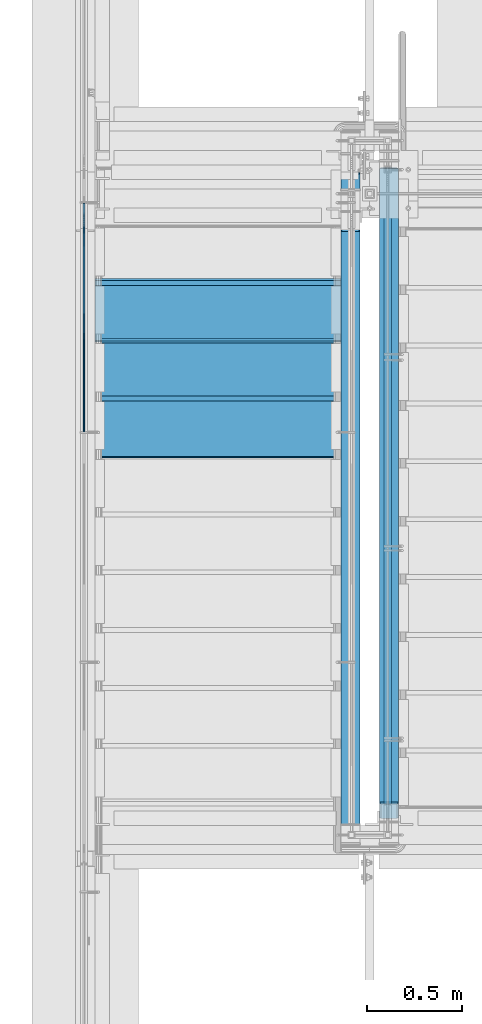
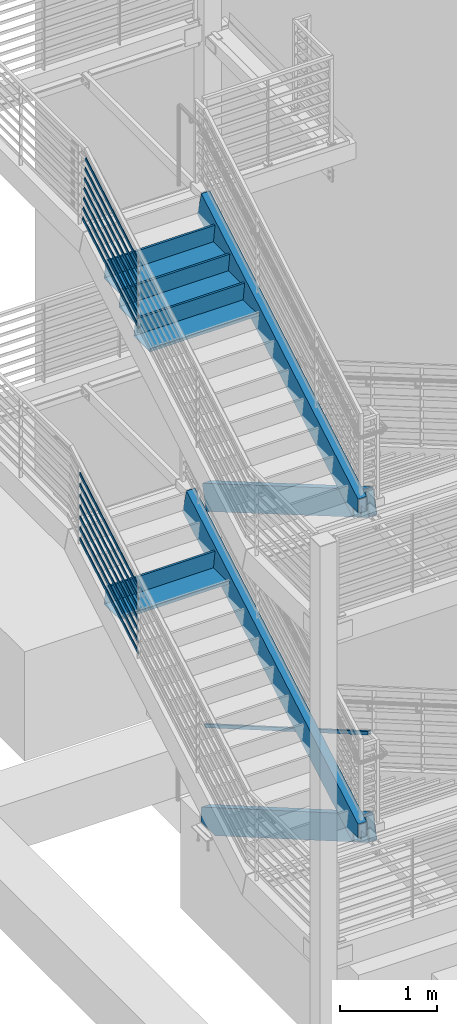
# One storey, part 756 of 1179: 19 members, 4 beams, 7 elements without a shape of their own.
"""IFC2X3 building model written with IfcOpenShell, lengths in millimetres."""

from ifc_helpers import new_model, si_unit, frame, origin_with_axes, place, context, subcontext, project, spatial, faceted_brep, material, type_object, element, aggregate, save


model = new_model("IFC2X3")

# Units and contexts
model_context = context("Model", 3, precision=1e-05, world=origin_with_axes())
body_context = subcontext(model_context, "Body", "Model", "MODEL_VIEW")
ifc_project = project(units=[si_unit("LENGTHUNIT", "METRE", prefix="MILLI"), si_unit("AREAUNIT", "SQUARE_METRE"), si_unit("VOLUMEUNIT", "CUBIC_METRE"), si_unit("MASSUNIT", "GRAM", prefix="KILO"), si_unit("TIMEUNIT", "SECOND"), si_unit("PLANEANGLEUNIT", "RADIAN"), si_unit("SOLIDANGLEUNIT", "STERADIAN"), si_unit("THERMODYNAMICTEMPERATUREUNIT", "DEGREE_CELSIUS"), si_unit("LUMINOUSINTENSITYUNIT", "LUMEN")], contexts=[model_context])

# Site, building, storey
site_placement = place(None, origin_with_axes())
site = spatial("IfcSite", under=ifc_project, at=site_placement, CompositionType="ELEMENT")
building_placement = place(site_placement, origin_with_axes())
building = spatial("IfcBuilding", under=site, at=building_placement, Name="Undefined", CompositionType="ELEMENT")
storey_placement = place(building_placement, origin_with_axes())
storey = spatial("IfcBuildingStorey", under=building, at=storey_placement, Name="Undefined", CompositionType="ELEMENT", Elevation=0.0)

# Assembly, members
assembly_1_placement = place(storey_placement, origin_with_axes())
assembly_1 = element("IfcElementAssembly", 1, at=assembly_1_placement, inside=storey, Name="GUARDRAIL", AssemblyPlace="NOTDEFINED", PredefinedType="RIGID_FRAME")
ifc_material_1 = material(Name="STEEL/A36")
member_type_1 = type_object("IfcMemberType", PredefinedType="NOTDEFINED")
member_1_placement = place(assembly_1_placement, frame((-3257.54999923555, 35021.5788062136, 8312.7043180715), z_axis=(0.0, -0.503864876039814, 0.863782488068254), x_axis=(0.0, -0.863782488068254, -0.503864876039814)))
member_1 = element("IfcMember", 2, at=member_1_placement, type_object=member_type_1, material=ifc_material_1, Name="PLATE", context=body_context, shape_type="Brep", body=[
    faceted_brep([(18.8763599969243, 4.76249999999982, -19.0499999999556), (8.57620325272728, 4.76249999999982, 19.0499999999902), (1330.21645634527, 4.76249999999982, 19.0500000018892), (1352.44109280458, 4.76249999999982, -19.0499999980384), (8.57620325272728, -4.76249999999982, 19.0499999999902), (1330.21645634527, -4.76249999999982, 19.0500000018892), (18.8763599969243, -4.76249999999982, -19.0499999999556), (1352.44109280458, -4.76249999999982, -19.0499999980384)], [[[0, 1, 2, 3]], [[1, 4, 5, 2]], [[4, 6, 7, 5]], [[6, 0, 3, 7]], [[5, 7, 3, 2]], [[6, 4, 1, 0]]]),
])
member_2_placement = place(assembly_1_placement, frame((-3257.54999923555, 35012.0608889983, 8443.31717869681), z_axis=(0.0, -0.503871025834967, 0.863778900717086), x_axis=(0.0, -0.863778900717086, -0.503871025834967)))
member_2 = element("IfcMember", 3, at=member_2_placement, type_object=member_type_1, material=ifc_material_1, Name="PLATE", context=body_context, shape_type="Brep", body=[
    faceted_brep([(19.7452586949948, 4.76249999999982, -19.0499999999938), (9.44495643083064, 4.76249999999982, 19.0500000000411), (1319.20291756878, 4.76250000000005, 19.0500000022403), (1341.42791758705, 4.76250000000005, -19.0499999977765), (9.44495643083064, -4.76249999999982, 19.0500000000411), (1319.20291756878, -4.76250000000005, 19.0500000022403), (19.7452586949948, -4.76249999999982, -19.0499999999938), (1341.42791758705, -4.76250000000005, -19.0499999977765)], [[[0, 1, 2, 3]], [[1, 4, 5, 2]], [[4, 6, 7, 5]], [[6, 0, 3, 7]], [[5, 7, 3, 2]], [[6, 4, 1, 0]]]),
])
member_3_placement = place(assembly_1_placement, frame((-3257.54999923555, 35001.1751747216, 8573.15010229813), z_axis=(0.0, -0.503871025834967, 0.863778900717086), x_axis=(0.0, -0.863778900717086, -0.503871025834967)))
member_3 = element("IfcMember", 4, at=member_3_placement, type_object=member_type_1, material=ifc_material_1, Name="PLATE", context=body_context, shape_type="Brep", body=[
    faceted_brep([(19.0663619513143, 4.76249999999982, -19.0499999999956), (8.76605968715739, 4.76249999999982, 19.0500000000393), (1306.60048624325, 4.76250000000005, 19.0500000022148), (1328.82548626152, 4.76250000000005, -19.0499999978038), (8.76605968715739, -4.76249999999982, 19.0500000000393), (1306.60048624325, -4.76250000000005, 19.0500000022148), (19.0663619513143, -4.76249999999982, -19.0499999999956), (1328.82548626152, -4.76250000000005, -19.0499999978038)], [[[0, 1, 2, 3]], [[1, 4, 5, 2]], [[4, 6, 7, 5]], [[6, 0, 3, 7]], [[5, 7, 3, 2]], [[6, 4, 1, 0]]]),
])
member_4_placement = place(assembly_1_placement, frame((-3257.54999923555, 34990.3077024344, 8702.98295757165), z_axis=(0.0, -0.503864876039814, 0.863782488068254), x_axis=(0.0, -0.863782488068254, -0.503864876039814)))
member_4 = element("IfcMember", 5, at=member_4_placement, type_object=member_type_1, material=ifc_material_1, Name="PLATE", context=body_context, shape_type="Brep", body=[
    faceted_brep([(18.3874183770095, 4.76249999999982, -19.0500000000065), (8.0872616165725, 4.76249999999982, 19.0500000000284), (1294.01393621509, 4.76250000000005, 19.050000001429), (1316.238572744, 4.76250000000005, -19.0499999985877), (8.0872616165725, -4.76249999999982, 19.0500000000284), (1294.01393621509, -4.76250000000005, 19.050000001429), (18.3874183770095, -4.76249999999982, -19.0500000000065), (1316.238572744, -4.76250000000005, -19.0499999985877)], [[[0, 1, 2, 3]], [[1, 4, 5, 2]], [[4, 6, 7, 5]], [[6, 0, 3, 7]], [[5, 7, 3, 2]], [[6, 4, 1, 0]]]),
])
member_5_placement = place(assembly_1_placement, frame((-3257.54999923555, 34979.4218093651, 8832.81588117843), z_axis=(0.0, -0.503864876039814, 0.863782488068254), x_axis=(0.0, -0.863782488068254, -0.503864876039814)))
member_5 = element("IfcMember", 6, at=member_5_placement, type_object=member_type_1, material=ifc_material_1, Name="PLATE", context=body_context, shape_type="Brep", body=[
    faceted_brep([(17.7085133596411, 4.76249999999982, -19.0499999999993), (7.40835659919685, 4.76249999999982, 19.0500000000284), (1281.41135022522, 4.76250000000005, 19.0500000014144), (1303.63598675413, 4.76250000000005, -19.0499999986005), (7.40835659919685, -4.76249999999982, 19.0500000000284), (1281.41135022522, -4.76250000000005, 19.0500000014144), (17.7085133596411, -4.76249999999982, -19.0499999999993), (1303.63598675413, -4.76250000000005, -19.0499999986005)], [[[0, 1, 2, 3]], [[1, 4, 5, 2]], [[4, 6, 7, 5]], [[6, 0, 3, 7]], [[5, 7, 3, 2]], [[6, 4, 1, 0]]]),
])
member_6_placement = place(assembly_1_placement, frame((-3257.54999923555, 34968.5359162859, 8962.6488047794), z_axis=(0.0, -0.503864876039814, 0.863782488068254), x_axis=(0.0, -0.863782488068254, -0.503864876039814)))
member_6 = element("IfcMember", 7, at=member_6_placement, type_object=member_type_1, material=ifc_material_1, Name="PLATE", context=body_context, shape_type="Brep", body=[
    faceted_brep([(17.0296083222929, 4.76249999999982, -19.0499999999738), (6.72945152641478, 4.76249999999982, 19.0499999999975), (1268.80876485228, 4.76250000000005, 19.0500000008888), (1291.03340142537, 4.76250000000005, -19.0499999990752), (6.72945152641478, -4.76249999999982, 19.0499999999975), (1268.80876485228, -4.76250000000005, 19.0500000008888), (17.0296083222929, -4.76249999999982, -19.0499999999738), (1291.03340142537, -4.76250000000005, -19.0499999990752)], [[[0, 1, 2, 3]], [[1, 4, 5, 2]], [[4, 6, 7, 5]], [[6, 0, 3, 7]], [[5, 7, 3, 2]], [[6, 4, 1, 0]]]),
])
member_7_placement = place(assembly_1_placement, frame((-3257.54999923555, 34957.6501403356, 9092.49219327407), z_axis=(0.0, -0.503871025834967, 0.863778900717086), x_axis=(0.0, -0.863778900717086, -0.503871025834967)))
member_7 = element("IfcMember", 8, at=member_7_placement, type_object=member_type_1, material=ifc_material_1, Name="PLATE", context=body_context, shape_type="Brep", body=[
    faceted_brep([(16.3714083730374, 4.76249999999982, -19.0499999999956), (6.07110610888049, 4.76249999999982, 19.0500000000393), (1256.21139436502, 4.76249999999982, 19.0500000021311), (1278.43639438329, 4.76249999999982, -19.0499999978838), (6.07110610888049, -4.76249999999982, 19.0500000000393), (1256.21139436502, -4.76250000000027, 19.0500000021311), (16.3714083730374, -4.76249999999982, -19.0499999999956), (1278.43639438329, -4.76250000000027, -19.0499999978838)], [[[0, 1, 2, 3]], [[1, 4, 5, 2]], [[4, 6, 7, 5]], [[6, 0, 3, 7]], [[5, 7, 3, 2]], [[6, 4, 1, 0]]]),
])
aggregate(assembly_1, [member_1, member_2, member_3, member_4, member_5, member_6, member_7])

assembly_2_placement = place(storey_placement, origin_with_axes())
assembly_2 = element("IfcElementAssembly", 9, at=assembly_2_placement, inside=storey, Name="GUARDRAIL", AssemblyPlace="NOTDEFINED", PredefinedType="RIGID_FRAME")
member_8_placement = place(assembly_2_placement, frame((-3257.54999923555, 35078.4786384036, 4257.75483876794), z_axis=(0.0, -0.501065882891537, 0.865409140812671), x_axis=(0.0, -0.86540914081267, -0.501065882891538)))
member_8 = element("IfcMember", 10, at=member_8_placement, type_object=member_type_1, material=ifc_material_1, Name="PLATE", context=body_context, shape_type="Brep", body=[
    faceted_brep([(27.5628128089447, 4.76250000000005, -19.0499999999756), (5.50317738577724, 4.76250000000005, 19.0499999999902), (1393.52680304928, 4.76249999999982, 19.0499999980784), (1415.58643847238, 4.76249999999982, -19.0500000019292), (5.50317738577724, -4.76250000000005, 19.0499999999902), (1393.52680304928, -4.76250000000027, 19.0499999980784), (27.5628128089447, -4.76250000000005, -19.0499999999756), (1415.58643847238, -4.76250000000027, -19.0500000019292)], [[[0, 1, 2, 3]], [[1, 4, 5, 2]], [[4, 6, 7, 5]], [[6, 0, 3, 7]], [[5, 7, 3, 2]], [[6, 4, 1, 0]]]),
])
member_9_placement = place(assembly_2_placement, frame((-3257.54999923555, 35078.4786384036, 4393.85525773245), z_axis=(0.0, -0.501065882891537, 0.865409140812671), x_axis=(0.0, -0.86540914081267, -0.501065882891538)))
member_9 = element("IfcMember", 11, at=member_9_placement, type_object=member_type_1, material=ifc_material_1, Name="PLATE", context=body_context, shape_type="Brep", body=[
    faceted_brep([(27.5628128089447, 4.76250000000005, -19.0499999999756), (5.50317738577724, 4.76250000000005, 19.0499999999902), (1393.52680304928, 4.76249999999982, 19.0499999980784), (1415.58643847238, 4.76249999999982, -19.0500000019292), (5.50317738577724, -4.76250000000005, 19.0499999999902), (1393.52680304928, -4.76250000000027, 19.0499999980784), (27.5628128089447, -4.76250000000005, -19.0499999999756), (1415.58643847238, -4.76250000000027, -19.0500000019292)], [[[0, 1, 2, 3]], [[1, 4, 5, 2]], [[4, 6, 7, 5]], [[6, 0, 3, 7]], [[5, 7, 3, 2]], [[6, 4, 1, 0]]]),
])
member_10_placement = place(assembly_2_placement, frame((-3257.54999923555, 35078.4786384036, 4529.95567669695), z_axis=(0.0, -0.501065882891537, 0.865409140812671), x_axis=(0.0, -0.86540914081267, -0.501065882891538)))
member_10 = element("IfcMember", 12, at=member_10_placement, type_object=member_type_1, material=ifc_material_1, Name="PLATE", context=body_context, shape_type="Brep", body=[
    faceted_brep([(27.5628128089447, 4.76250000000005, -19.0499999999756), (5.50317738577724, 4.76250000000005, 19.0499999999902), (1393.52680304928, 4.76249999999982, 19.0499999980784), (1415.58643847238, 4.76249999999982, -19.0500000019292), (5.50317738577724, -4.76250000000005, 19.0499999999902), (1393.52680304928, -4.76250000000027, 19.0499999980784), (27.5628128089447, -4.76250000000005, -19.0499999999756), (1415.58643847238, -4.76250000000027, -19.0500000019292)], [[[0, 1, 2, 3]], [[1, 4, 5, 2]], [[4, 6, 7, 5]], [[6, 0, 3, 7]], [[5, 7, 3, 2]], [[6, 4, 1, 0]]]),
])
member_11_placement = place(assembly_2_placement, frame((-3257.54999923555, 35078.4786384036, 4666.05609566146), z_axis=(0.0, -0.501065882891537, 0.865409140812671), x_axis=(0.0, -0.86540914081267, -0.501065882891538)))
member_11 = element("IfcMember", 13, at=member_11_placement, type_object=member_type_1, material=ifc_material_1, Name="PLATE", context=body_context, shape_type="Brep", body=[
    faceted_brep([(27.5628128089447, 4.76250000000005, -19.0499999999756), (5.50317738577724, 4.76250000000005, 19.0499999999902), (1393.52680304928, 4.76249999999982, 19.0499999980784), (1415.58643847238, 4.76249999999982, -19.0500000019292), (5.50317738577724, -4.76250000000005, 19.0499999999902), (1393.52680304928, -4.76250000000027, 19.0499999980784), (27.5628128089447, -4.76250000000005, -19.0499999999756), (1415.58643847238, -4.76250000000027, -19.0500000019292)], [[[0, 1, 2, 3]], [[1, 4, 5, 2]], [[4, 6, 7, 5]], [[6, 0, 3, 7]], [[5, 7, 3, 2]], [[6, 4, 1, 0]]]),
])
member_12_placement = place(assembly_2_placement, frame((-3257.54999923555, 35078.4786384036, 4802.15651462597), z_axis=(0.0, -0.501065882891537, 0.865409140812671), x_axis=(0.0, -0.86540914081267, -0.501065882891538)))
member_12 = element("IfcMember", 14, at=member_12_placement, type_object=member_type_1, material=ifc_material_1, Name="PLATE", context=body_context, shape_type="Brep", body=[
    faceted_brep([(27.5628128089447, 4.76250000000005, -19.0499999999756), (5.50317738577724, 4.76250000000005, 19.0499999999902), (1393.52680304928, 4.76249999999982, 19.0499999980784), (1415.58643847238, 4.76249999999982, -19.0500000019292), (5.50317738577724, -4.76250000000005, 19.0499999999902), (1393.52680304928, -4.76250000000027, 19.0499999980784), (27.5628128089447, -4.76250000000005, -19.0499999999756), (1415.58643847238, -4.76250000000027, -19.0500000019292)], [[[0, 1, 2, 3]], [[1, 4, 5, 2]], [[4, 6, 7, 5]], [[6, 0, 3, 7]], [[5, 7, 3, 2]], [[6, 4, 1, 0]]]),
])
member_13_placement = place(assembly_2_placement, frame((-3257.54999923555, 35078.4786384036, 4938.25693359048), z_axis=(0.0, -0.501065882891537, 0.865409140812671), x_axis=(0.0, -0.86540914081267, -0.501065882891538)))
member_13 = element("IfcMember", 15, at=member_13_placement, type_object=member_type_1, material=ifc_material_1, Name="PLATE", context=body_context, shape_type="Brep", body=[
    faceted_brep([(27.5628128089447, 4.76250000000005, -19.0499999999756), (5.50317738577724, 4.76250000000005, 19.0499999999902), (1393.52680304928, 4.76249999999982, 19.0499999980784), (1415.58643847238, 4.76249999999982, -19.0500000019292), (5.50317738577724, -4.76250000000005, 19.0499999999902), (1393.52680304928, -4.76250000000027, 19.0499999980784), (27.5628128089447, -4.76250000000005, -19.0499999999756), (1415.58643847238, -4.76250000000027, -19.0500000019292)], [[[0, 1, 2, 3]], [[1, 4, 5, 2]], [[4, 6, 7, 5]], [[6, 0, 3, 7]], [[5, 7, 3, 2]], [[6, 4, 1, 0]]]),
])
member_14_placement = place(assembly_2_placement, frame((-3257.54999923555, 35078.4786384036, 5074.35735255499), z_axis=(0.0, -0.501065882891537, 0.865409140812671), x_axis=(0.0, -0.86540914081267, -0.501065882891538)))
member_14 = element("IfcMember", 16, at=member_14_placement, type_object=member_type_1, material=ifc_material_1, Name="PLATE", context=body_context, shape_type="Brep", body=[
    faceted_brep([(27.5628128089447, 4.76250000000005, -19.0499999999756), (5.50317738577724, 4.76250000000005, 19.0499999999902), (1393.52680304928, 4.76249999999982, 19.0499999980784), (1415.58643847238, 4.76249999999982, -19.0500000019292), (5.50317738577724, -4.76250000000005, 19.0499999999902), (1393.52680304928, -4.76250000000027, 19.0499999980784), (27.5628128089447, -4.76250000000005, -19.0499999999756), (1415.58643847238, -4.76250000000027, -19.0500000019292)], [[[0, 1, 2, 3]], [[1, 4, 5, 2]], [[4, 6, 7, 5]], [[6, 0, 3, 7]], [[5, 7, 3, 2]], [[6, 4, 1, 0]]]),
])
aggregate(assembly_2, [member_8, member_9, member_10, member_11, member_12, member_13, member_14])

# Assembly, member
assembly_3_placement = place(storey_placement, origin_with_axes())
assembly_3 = element("IfcElementAssembly", 17, at=assembly_3_placement, inside=storey, Name="GUARDRAIL", AssemblyPlace="NOTDEFINED", PredefinedType="RIGID_FRAME")
ifc_material_2 = material()
member_type_2 = type_object("IfcMemberType", Name="HSS1-1/2X1-1/2X1/4", PredefinedType="NOTDEFINED")
member_15_placement = place(assembly_3_placement, frame((-1657.34999921452, 35242.4999994261, 1243.27806215934), z_axis=(0.0, 0.501075923252298, 0.865403327435744), x_axis=(0.0, -0.865403327435743, 0.501075923252299)))
member_15 = element("IfcMember", 18, at=member_15_placement, type_object=member_type_2, material=ifc_material_2, Name="GUARDRAIL", ObjectType="HSS1-1/2X1-1/2X1/4", context=body_context, shape_type="Brep", body=[
    faceted_brep([(7.32182813537293, 12.6999993300001, -12.699999329976), (7.32182813537293, -12.6999993300001, -12.699999329976), (3870.8560406721, -12.6999993300001, -12.6999993233439), (3870.8560406721, 12.6999993300001, -12.6999993233439), (-7.3218304676775, -12.6999993300001, 12.6999993299796), (3877.66986232676, -12.6999993300001, 12.6999993366444), (-7.3218304676775, 12.6999993300001, 12.6999993299796), (3877.66986232676, 12.6999993300001, 12.6999993366444), (10.9827429245051, 19.0499992350001, -19.0499992349651), (-10.9827452568097, 19.0499992350001, 19.0499992349687), (3879.37331780481, 19.0499992350001, 19.049999241648), (3869.15258519406, 19.0499992350001, -19.0499992283403), (-10.9827452568097, -19.0499992350001, 19.0499992349687), (3879.37331780481, -19.0499992350001, 19.049999241648), (10.9827429245051, -19.0499992350001, -19.0499992349651), (3869.15258519406, -19.0499992350001, -19.0499992283403)], [[[0, 1, 2, 3]], [[1, 4, 5, 2]], [[4, 6, 7, 5]], [[6, 0, 3, 7]], [[8, 9, 10, 11]], [[9, 12, 13, 10]], [[12, 14, 15, 13]], [[14, 8, 11, 15]], [[13, 15, 11, 10], [5, 7, 3, 2]], [[14, 12, 9, 8], [6, 4, 1, 0]]]),
])
aggregate(assembly_3, [member_15])

# Assembly, beam
assembly_4_placement = place(storey_placement, origin_with_axes())
assembly_4 = element("IfcElementAssembly", 19, at=assembly_4_placement, inside=storey, Name="STRINGER", AssemblyPlace="NOTDEFINED", PredefinedType="RIGID_FRAME")
beam_type_1 = type_object("IfcBeamType", PredefinedType="NOTDEFINED")
beam_1_placement = place(assembly_4_placement, frame((-2552.70000000051, 34658.300000202, 3880.90833333393), z_axis=(1.0, 0.0, 0.0), x_axis=(0.0, -1.0, 0.0)))
beam_1 = element("IfcBeam", 20, at=beam_1_placement, type_object=beam_type_1, material=ifc_material_1, Name="TREAD", context=body_context, shape_type="Brep", body=[
    faceted_brep([(-5.47515810467303e-10, -1.58750000000146, -647.7), (-5.47515810467303e-10, -1.58750000000146, 647.7), (5.49334799870849e-10, 1.58749999999418, 647.7), (5.49334799870849e-10, 1.58749999999418, -647.7), (21.7353257776667, 1.58750000000009, 647.7), (21.7353257776667, 1.58750000000009, -647.7), (25.4000000001688, -1.58750000000009, -647.7), (25.4000000001688, -1.58750000000009, 647.7), (-10.9762326817727, 228.864583333333, 647.7), (-10.9762326817727, 228.864583333333, -647.7), (-7.31154422789405, 225.689583333333, -647.7), (-7.31154422789405, 225.689583333333, 647.7), (319.223767229007, 228.864583333333, 647.7), (319.223767229007, 228.864583333333, -647.7), (316.473021803613, 225.689583333333, -647.7), (316.473021803613, 225.689583333333, 647.7), (325.043366447484, 188.430492929979, 647.7), (325.043366447484, 188.430492929979, -647.7), (321.900749692417, 187.978182272578, 647.7), (321.900749692417, 187.978182272578, -647.7)], [[[0, 1, 2, 3]], [[3, 2, 4, 5]], [[1, 0, 6, 7]], [[5, 4, 8, 9]], [[7, 6, 10, 11]], [[9, 8, 12, 13]], [[11, 10, 14, 15]], [[13, 12, 16, 17]], [[12, 8, 4, 2, 1, 7, 11, 15, 18, 16]], [[15, 14, 19, 18]], [[14, 10, 6, 0, 3, 5, 9, 13, 17, 19]], [[18, 19, 17, 16]]]),
])

# Assembly, member
assembly_5_placement = place(storey_placement, origin_with_axes())
assembly_5 = element("IfcElementAssembly", 21, at=assembly_5_placement, inside=storey, Name="STRINGER", AssemblyPlace="NOTDEFINED", PredefinedType="RIGID_FRAME")
member_type_3 = type_object("IfcMemberType", Name="HSS12X4X3/8", PredefinedType="NOTDEFINED")
member_16_placement = place(assembly_5_placement, frame((-1854.19999999955, 31647.9562107233, 6110.41009553194), z_axis=(0.0, -0.503871025834967, 0.863778900717086), x_axis=(0.0, 0.863778900717087, 0.503871025834967)))
member_16 = element("IfcMember", 22, at=member_16_placement, type_object=member_type_3, material=ifc_material_2, Name="STRINGER", ObjectType="HSS12X4X3/8", context=body_context, shape_type="Brep", body=[
    faceted_brep([(3879.06301396363, 41.2749999999999, 143.205096364456), (3872.0238482502, 50.4699036320367, 152.400000003649), (3872.0238482502, -50.4699036320367, 152.400000003649), (3879.06301396363, -41.2750000000001, 143.205096364456), (3871.68190144677, -50.8000000000002, 152.400000003652), (3789.27948303458, -50.8000000000029, -152.400000003301), (3789.62142983938, -50.4699036320362, -152.400000003296), (3801.63226414554, -41.2750000000001, -143.205096371272), (3789.62142983938, 50.4699036320358, -152.400000003296), (3801.63226414554, 41.2749999999999, -143.205096371272), (3789.27948303458, 50.8000000000029, -152.400000003297), (3871.68190144677, 50.8000000000002, 152.400000003652), (59.8566244442954, 41.2750000000001, 7.21236151948506), (59.8566244442954, 50.8, 7.21236151948506), (147.616560767063, 50.8, -43.9809347105565), (147.616560767063, 41.2750000000001, -43.9809347105565), (144.549413627607, -50.8, 152.399999999803), (144.549413627607, 50.8, 152.399999999803), (138.99316362309, 41.2750000000001, 142.874999999809), (138.99316362309, -41.2750000000001, 142.874999999809), (59.8566244442954, -41.2750000000001, 7.21236151948506), (59.8566244442954, -50.8, 7.21236151948506), (147.616560767063, -41.2750000000001, -43.9809347105565), (147.616560767063, -50.8, -43.9809347105565), (89.9283559671712, -41.2750000000001, -142.875000000018), (89.9283559671712, 41.2750000000001, -142.875000000018), (84.3721059625786, 50.8, -152.400000000007), (84.3721059625786, -50.8, -152.400000000007), (3878.97377268072, -41.2750000000015, 142.874999996493), (3878.97377268072, 41.2750000000015, 142.874999996493), (3801.72150540223, 41.2750000000015, -142.875000003311), (3801.72150540223, -41.2750000000015, -142.875000003311)], [[[0, 1, 2, 3]], [[4, 5, 6, 7, 3, 2]], [[8, 9, 7, 6]], [[9, 8, 10, 11, 1, 0]], [[12, 13, 14, 15]], [[16, 17, 13, 12, 18, 19, 20, 21]], [[21, 20, 22, 23]], [[23, 22, 24, 25, 15, 14, 26, 27]], [[27, 26, 10, 8, 6, 5]], [[11, 17, 16, 4, 2, 1]], [[16, 21, 23, 27, 5, 4]], [[26, 14, 13, 17, 11, 10]], [[7, 9, 0, 3], [28, 29, 30, 31]], [[29, 28, 19, 18]], [[30, 29, 18, 12, 15, 25]], [[31, 30, 25, 24]], [[19, 28, 31, 24, 22, 20]]]),
])

assembly_6_placement = place(storey_placement, origin_with_axes())
assembly_6 = element("IfcElementAssembly", 23, at=assembly_6_placement, inside=storey, Name="STRINGER", AssemblyPlace="NOTDEFINED", PredefinedType="RIGID_FRAME")
member_17_placement = place(assembly_6_placement, frame((-1650.99999999798, 35179.4437911653, 4154.61009443416), z_axis=(0.0, 0.503871025834968, 0.863778900717086), x_axis=(0.0, -0.863778900717086, 0.503871025834967)))
member_17 = element("IfcMember", 24, at=member_17_placement, type_object=member_type_3, material=ifc_material_2, Name="STRINGER", ObjectType="HSS12X4X3/8", context=body_context, shape_type="Brep", body=[
    faceted_brep([(3879.16508860334, 41.2750000000001, 143.205894969626), (3872.12887500437, 50.4691050271292, 152.399999996775), (3872.12887500437, -50.4691050271292, 152.399999996775), (3879.16508860334, -41.2750000000001, 143.205894969626), (3789.62143215917, 50.4691050271292, -152.400000003574), (3801.63521856023, 41.2750000000001, -143.205894976443), (3801.63521856023, -41.2750000000001, -143.205894976443), (3789.62143215917, -50.4691050271292, -152.400000003574), (3789.27862830743, 50.8, -152.40000000357), (3871.78607115263, 50.8, 152.399999996775), (-79.9165841296781, 41.2750000000001, -143.205096368092), (-72.8774184357826, 50.4699036320364, -152.400000000143), (-72.8774184357826, -50.4699036320364, -152.400000000143), (-79.9165841296781, -41.2750000000001, -143.205096368092), (-2.48583431255611, 41.2750000000001, 143.205096368165), (9.52499998274288, 50.4699036320367, 152.400000000223), (9.86694677204468, 50.8000000000029, 152.39999999994), (-72.5354716336769, 50.8000000000029, -152.39999999987), (-72.5354716336769, -50.8000000000029, -152.400000000493), (9.86694677204105, -50.8000000000029, 152.400000000649), (9.52499998274288, -50.4699036320367, 152.400000000223), (-2.48583431255611, -41.2750000000001, 143.205096368165), (3871.78607115263, -50.8, 152.399999996775), (3789.27862830743, -50.8, -152.40000000357), (-79.8273428607608, 41.2750000000015, -142.874999999865), (-79.8273428607608, -41.2750000000015, -142.874999999865), (3801.7247897481, -41.2750000000001, -142.875000003569), (3801.7247897481, 41.2750000000001, -142.875000003569), (-2.57507558227371, -41.2750000000015, 142.874999999935), (3879.07551741547, -41.2750000000001, 142.874999996755), (-2.57507558227371, 41.2750000000015, 142.874999999935), (3879.07551741547, 41.2750000000001, 142.874999996755)], [[[0, 1, 2, 3]], [[4, 5, 6, 7]], [[5, 4, 8, 9, 1, 0]], [[10, 11, 12, 13]], [[14, 15, 16, 17, 11, 10]], [[18, 19, 20, 21, 13, 12]], [[21, 20, 15, 14]], [[22, 23, 7, 6, 3, 2]], [[24, 25, 26, 27]], [[25, 28, 29, 26]], [[28, 30, 31, 29]], [[30, 24, 27, 31]], [[17, 16, 9, 8]], [[9, 16, 15, 20, 19, 22, 2, 1]], [[23, 22, 19, 18]], [[23, 18, 12, 11, 17, 8, 4, 7]], [[6, 5, 0, 3], [29, 31, 27, 26]], [[21, 14, 10, 13], [30, 28, 25, 24]]]),
])
aggregate(assembly_6, [member_17])

assembly_7_placement = place(storey_placement, origin_with_axes())
assembly_7 = element("IfcElementAssembly", 25, at=assembly_7_placement, inside=storey, Name="STRINGER", AssemblyPlace="NOTDEFINED", PredefinedType="RIGID_FRAME")
member_18_placement = place(assembly_7_placement, frame((-1651.00000000639, 35399.1238371489, -31.6103837750855), z_axis=(0.0, 0.501075923252298, 0.865403327435744), x_axis=(0.0, -0.865403327435743, 0.501075923252299)))
member_18 = element("IfcMember", 26, at=member_18_placement, type_object=member_type_3, material=ifc_material_2, Name="STRINGER", ObjectType="HSS12X4X3/8", context=body_context, shape_type="Brep", body=[
    faceted_brep([(4048.31646912194, -41.2750000000001, -143.201090207578), (4036.32050096821, -50.4739097931888, -152.400000000773), (4036.32050096821, 50.4739097931867, -152.400000000773), (4048.31646912194, 41.2750000000001, -143.201090207578), (4125.2484842053, -41.2750000000001, 143.201090206228), (4118.19445235903, -50.4739097931808, 152.399999999412), (4117.85680264947, -50.8, 152.399999999412), (4035.98285125866, -50.8, -152.400000000773), (4125.2484842053, 41.2750000000001, 143.201090206228), (4118.19445235902, 50.473909793192, 152.399999999423), (4035.98285125866, 50.8, -152.400000000773), (4117.85680264947, 50.8, 152.399999999423), (390.290858818327, 50.8, -152.400000000172), (354.831229110539, 41.2750000000001, -142.87500000016), (126.957982972355, 41.2750000000001, -10.934442836151), (139.973697407153, 50.8, -7.46422406349666), (216.014954332284, 41.2750000000001, 142.875000000058), (232.53643842792, 50.8, 152.400000000067), (354.831229110539, -41.2750000000001, -142.87500000016), (390.290858818324, -50.8, -152.400000000904), (139.973697407251, -50.8, -7.46422406355487), (126.957982972355, -41.2750000000001, -10.934442836151), (232.53643842792, -50.8, 152.399999995516), (216.014954332284, -41.2750000000001, 142.875000000058), (4048.40406194918, 41.2750000000001, -142.875000000768), (4125.16089137807, 41.2750000000001, 142.874999999418), (4048.40406194918, -41.2750000000001, -142.875000000768), (4125.16089137807, -41.2750000000001, 142.874999999418)], [[[0, 1, 2, 3]], [[4, 5, 6, 7, 1, 0]], [[8, 9, 5, 4]], [[10, 11, 9, 8, 3, 2]], [[12, 13, 14, 15]], [[16, 17, 15, 14]], [[18, 19, 20, 21]], [[22, 23, 21, 20]], [[19, 18, 13, 12]], [[9, 11, 17, 22, 6, 5]], [[7, 19, 12, 10, 2, 1]], [[12, 15, 17, 11, 10]], [[13, 24, 25, 16, 14]], [[26, 24, 13, 18]], [[8, 4, 0, 3], [27, 25, 24, 26]], [[25, 27, 23, 16]], [[23, 22, 17, 16]], [[27, 26, 18, 21, 23]], [[22, 20, 19, 7, 6]]]),
])
aggregate(assembly_7, [member_18])

# Member
member_19_placement = place(assembly_4_placement, frame((-1854.20000000029, 31647.6170990034, 2036.63664694006), z_axis=(0.0, -0.501065882891537, 0.865409140812671), x_axis=(0.0, 0.86540914081267, 0.501065882891538)))
member_19 = element("IfcMember", 27, at=member_19_placement, type_object=member_type_3, material=ifc_material_2, Name="STRINGER", ObjectType="HSS12X4X3/8", context=body_context, shape_type="Brep", body=[
    faceted_brep([(4147.03907826185, -41.2750000000001, -143.201075876426), (4223.96930456703, -41.2750000000001, 143.201075872639), (4216.91521932065, -50.4739241277712, 152.399999994117), (4216.57758497996, -50.8000000000006, 152.399999994119), (4134.70552912131, -50.8, -152.400000001802), (4135.04316346456, -50.4739241253865, -152.400000001806), (4135.04316346456, 50.4739241253867, -152.400000001806), (4147.03907826185, 41.2750000000001, -143.201075876426), (4223.96930456703, 41.2750000000001, 143.201075872639), (4216.91521932065, 50.4739241277712, 152.399999994117), (4134.70552912131, 50.8, -152.400000001802), (4216.57758497996, 50.7999999999997, 152.399999994119), (60.2508687245609, 41.2750000000001, 7.45161799662674), (60.2508687245609, 50.8, 7.45161799662674), (148.17643744055, 50.8, -43.4566757108096), (148.17643744055, 41.2750000000001, -43.4566757108096), (144.174975343019, -50.8, 152.399999999867), (144.174975343019, 50.8, 152.399999999867), (138.660066487242, 41.2750000000001, 142.874999999874), (138.660066487242, -41.2750000000001, 142.874999999874), (60.2508687245609, -41.2750000000001, 7.45161799662674), (60.2508687245609, -50.8, 7.45161799662674), (148.17643744055, -41.2750000000001, -43.4566757108096), (148.17643744055, -50.8, -43.4566757108096), (90.6139180651371, -41.2750000000001, -142.87499999998), (90.6139180651371, 41.2750000000001, -142.87499999998), (85.0990092093598, 50.8, -152.399999999974), (85.0990092093598, -50.8, -152.399999999974), (4223.88171761744, -41.2750000000001, 142.874999998026), (4223.88171761744, 41.2750000000001, 142.874999998026), (4147.12666521143, 41.2750000000001, -142.875000001815), (4147.12666521143, -41.2750000000001, -142.875000001815)], [[[0, 1, 2, 3, 4, 5]], [[6, 7, 0, 5]], [[8, 9, 2, 1]], [[10, 11, 9, 8, 7, 6]], [[12, 13, 14, 15]], [[16, 17, 13, 12, 18, 19, 20, 21]], [[21, 20, 22, 23]], [[23, 22, 24, 25, 15, 14, 26, 27]], [[27, 26, 10, 6, 5, 4]], [[9, 11, 17, 16, 3, 2]], [[16, 21, 23, 27, 4, 3]], [[26, 14, 13, 17, 11, 10]], [[7, 8, 1, 0], [28, 29, 30, 31]], [[29, 28, 19, 18]], [[30, 29, 18, 12, 15, 25]], [[31, 30, 25, 24]], [[19, 28, 31, 24, 22, 20]]]),
])

aggregate(assembly_4, [member_19, beam_1])

# Beam
beam_type_2 = type_object("IfcBeamType", PredefinedType="NOTDEFINED")
beam_2_placement = place(assembly_5_placement, frame((-2552.69999999873, 34658.3000002385, 7967.66249999919), z_axis=(1.0, 0.0, 0.0), x_axis=(0.0, -1.0, 0.0)))
beam_2 = element("IfcBeam", 28, at=beam_2_placement, type_object=beam_type_2, material=ifc_material_1, Name="TREAD", context=body_context, shape_type="Brep", body=[
    faceted_brep([(-5.47515810467303e-10, -1.58750000000146, -647.7), (-5.47515810467303e-10, -1.58750000000146, 647.7), (5.49334799870849e-10, 1.58749999999418, 647.7), (5.49334799870849e-10, 1.58749999999418, -647.7), (21.7391942417962, 1.58749999999964, 647.7), (21.7391942417962, 1.58749999999964, -647.7), (25.4000000001688, -1.58750000000009, -647.7), (25.4000000001688, -1.58750000000009, 647.7), (-10.9179486153444, 230.1875, 647.7), (-10.9179486153444, 230.1875, -647.7), (-7.25714285782306, 227.012500000001, -647.7), (-7.25714285782306, 227.012500000001, 647.7), (319.2820511338, 230.1875, 647.7), (319.2820511338, 230.1875, -647.7), (316.528388233419, 227.012500000001, -647.7), (316.528388233419, 227.012500000001, 647.7), (325.059631548502, 189.744437097058, 647.7), (325.059631548502, 189.744437097058, -647.7), (321.916541906132, 189.295424291005, 647.7), (321.916541906132, 189.295424291005, -647.7)], [[[0, 1, 2, 3]], [[3, 2, 4, 5]], [[1, 0, 6, 7]], [[5, 4, 8, 9]], [[7, 6, 10, 11]], [[9, 8, 12, 13]], [[11, 10, 14, 15]], [[13, 12, 16, 17]], [[12, 8, 4, 2, 1, 7, 11, 15, 18, 16]], [[15, 14, 19, 18]], [[14, 10, 6, 0, 3, 5, 9, 13, 17, 19]], [[18, 19, 17, 16]]]),
])

beam_3_placement = place(assembly_5_placement, frame((-2552.69999999853, 34353.5000004906, 7789.86249999919), z_axis=(1.0, 0.0, 0.0), x_axis=(0.0, -1.0, 0.0)))
beam_3 = element("IfcBeam", 29, at=beam_3_placement, type_object=beam_type_2, material=ifc_material_1, Name="TREAD", context=body_context, shape_type="Brep", body=[
    faceted_brep([(-5.47515810467303e-10, -1.58750000000146, -647.7), (-5.47515810467303e-10, -1.58750000000146, 647.7), (5.49334799870849e-10, 1.58749999999418, 647.7), (5.49334799870849e-10, 1.58749999999418, -647.7), (21.7391942417962, 1.58749999999964, 647.7), (21.7391942417962, 1.58749999999964, -647.7), (25.4000000001688, -1.58750000000009, -647.7), (25.4000000001688, -1.58750000000009, 647.7), (-10.9179486153444, 230.1875, 647.7), (-10.9179486153444, 230.1875, -647.7), (-7.25714285782306, 227.012500000001, -647.7), (-7.25714285782306, 227.012500000001, 647.7), (319.2820511338, 230.1875, 647.7), (319.2820511338, 230.1875, -647.7), (316.528388233419, 227.012500000001, -647.7), (316.528388233419, 227.012500000001, 647.7), (325.059631548502, 189.744437097058, 647.7), (325.059631548502, 189.744437097058, -647.7), (321.916541906132, 189.295424291005, 647.7), (321.916541906132, 189.295424291005, -647.7)], [[[0, 1, 2, 3]], [[3, 2, 4, 5]], [[1, 0, 6, 7]], [[5, 4, 8, 9]], [[7, 6, 10, 11]], [[9, 8, 12, 13]], [[11, 10, 14, 15]], [[13, 12, 16, 17]], [[12, 8, 4, 2, 1, 7, 11, 15, 18, 16]], [[15, 14, 19, 18]], [[14, 10, 6, 0, 3, 5, 9, 13, 17, 19]], [[18, 19, 17, 16]]]),
])

beam_4_placement = place(assembly_5_placement, frame((-2552.69999999833, 34048.7000007426, 7612.06249999919), z_axis=(1.0, 0.0, 0.0), x_axis=(0.0, -1.0, 0.0)))
beam_4 = element("IfcBeam", 30, at=beam_4_placement, type_object=beam_type_2, material=ifc_material_1, Name="TREAD", context=body_context, shape_type="Brep", body=[
    faceted_brep([(-5.47515810467303e-10, -1.58750000000146, -647.7), (-5.47515810467303e-10, -1.58750000000146, 647.7), (5.49334799870849e-10, 1.58749999999418, 647.7), (5.49334799870849e-10, 1.58749999999418, -647.7), (21.7391942417962, 1.58749999999964, 647.7), (21.7391942417962, 1.58749999999964, -647.7), (25.4000000001688, -1.58750000000009, -647.7), (25.4000000001688, -1.58750000000009, 647.7), (-10.9179486153444, 230.1875, 647.7), (-10.9179486153444, 230.1875, -647.7), (-7.25714285782306, 227.012500000001, -647.7), (-7.25714285782306, 227.012500000001, 647.7), (319.2820511338, 230.1875, 647.7), (319.2820511338, 230.1875, -647.7), (316.528388233419, 227.012500000001, -647.7), (316.528388233419, 227.012500000001, 647.7), (325.059631548502, 189.744437097058, 647.7), (325.059631548502, 189.744437097058, -647.7), (321.916541906132, 189.295424291005, 647.7), (321.916541906132, 189.295424291005, -647.7)], [[[0, 1, 2, 3]], [[3, 2, 4, 5]], [[1, 0, 6, 7]], [[5, 4, 8, 9]], [[7, 6, 10, 11]], [[9, 8, 12, 13]], [[11, 10, 14, 15]], [[13, 12, 16, 17]], [[12, 8, 4, 2, 1, 7, 11, 15, 18, 16]], [[15, 14, 19, 18]], [[14, 10, 6, 0, 3, 5, 9, 13, 17, 19]], [[18, 19, 17, 16]]]),
])

aggregate(assembly_5, [beam_2, beam_3, member_16, beam_4])

save(model, "model.ifc")
